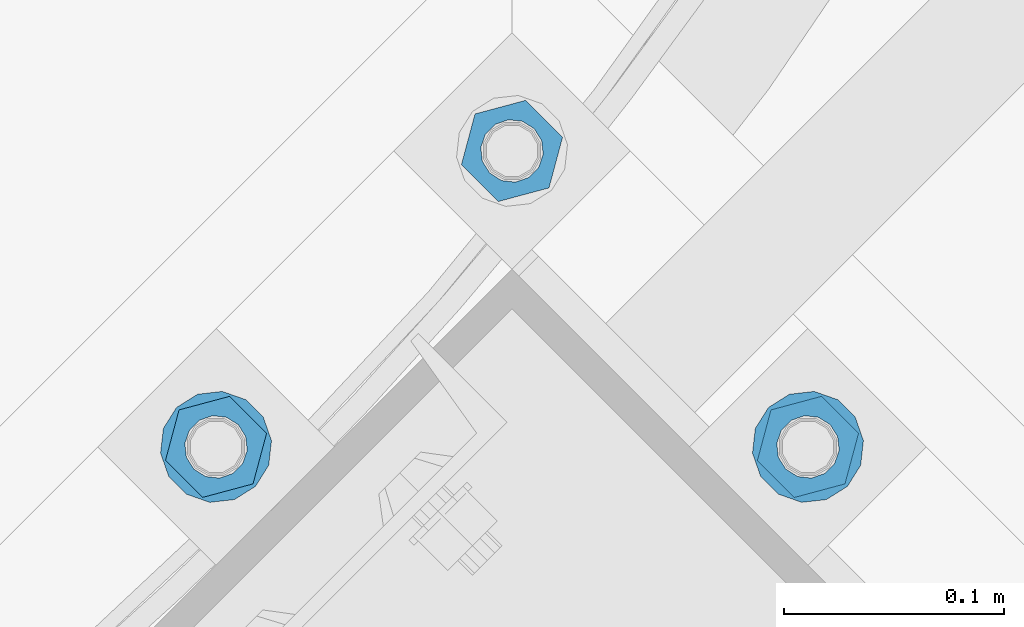
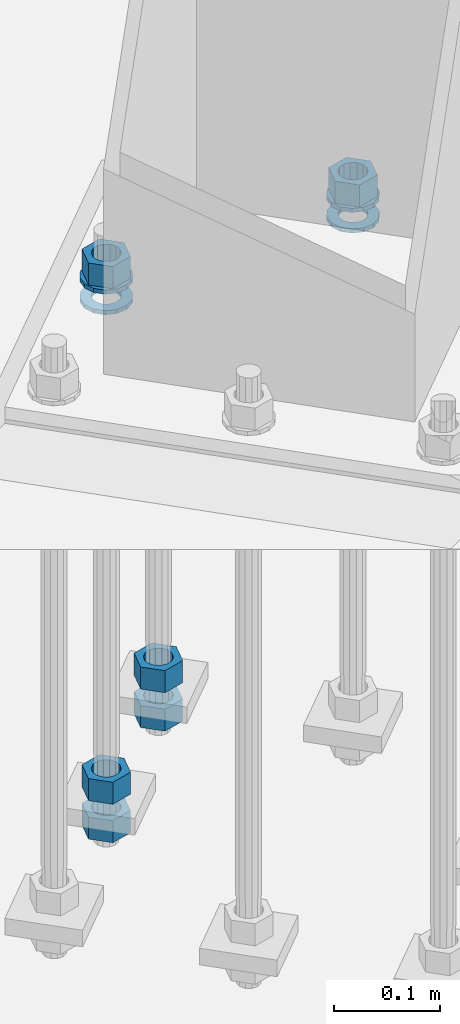
# One storey, part 868 of 1876: 10 columns, 1 element without a shape of its own.
"""IFC2X3 building model written with IfcOpenShell, lengths in millimetres."""

from ifc_helpers import new_model, si_unit, frame, origin_with_axes, place, context, subcontext, project, spatial, faceted_brep, material, type_object, element, aggregate, save


model = new_model("IFC2X3")

# Units and contexts
model_context = context("Model", 3, precision=1e-05, world=origin_with_axes())
body_context = subcontext(model_context, "Body", "Model", "MODEL_VIEW")
ifc_project = project(units=[si_unit("LENGTHUNIT", "METRE", prefix="MILLI"), si_unit("AREAUNIT", "SQUARE_METRE"), si_unit("VOLUMEUNIT", "CUBIC_METRE"), si_unit("MASSUNIT", "GRAM", prefix="KILO"), si_unit("TIMEUNIT", "SECOND"), si_unit("PLANEANGLEUNIT", "RADIAN"), si_unit("SOLIDANGLEUNIT", "STERADIAN"), si_unit("THERMODYNAMICTEMPERATUREUNIT", "DEGREE_CELSIUS"), si_unit("LUMINOUSINTENSITYUNIT", "LUMEN")], contexts=[model_context])

# Site, building, storey
site_placement = place(None, origin_with_axes())
site = spatial("IfcSite", under=ifc_project, at=site_placement, CompositionType="ELEMENT")
building_placement = place(site_placement, origin_with_axes())
building = spatial("IfcBuilding", under=site, at=building_placement, Name="Undefined", CompositionType="ELEMENT")
storey_placement = place(building_placement, origin_with_axes())
storey = spatial("IfcBuildingStorey", under=building, at=storey_placement, Name="Undefined", CompositionType="ELEMENT", Elevation=0.0)

# Assembly, columns
assembly_placement = place(storey_placement, origin_with_axes())
assembly = element("IfcElementAssembly", 1, at=assembly_placement, inside=storey, Name="TEMPLATE", AssemblyPlace="NOTDEFINED", PredefinedType="RIGID_FRAME")
ifc_material_1 = material(Name="STEEL/A563")
column_type_1 = type_object("IfcColumnType", Name="1_HEAVY_HEX_NUT", PredefinedType="NOTDEFINED")
column_1_placement = place(assembly_placement, frame((6714.97873267278, -14852.8285485942, 87.3125), z_axis=(0.707106781186548, 0.707106781186547, 0.0), x_axis=(0.0, 0.0, -1.0)))
column_1 = element("IfcColumn", 2, at=column_1_placement, type_object=column_type_1, material=ifc_material_1, Name="NUT", ObjectType="1_HEAVY_HEX_NUT", context=body_context, shape_type="Brep", body=[
    faceted_brep([(0.0, -23.8099994659442, 9.09494701772928e-13), (0.0, -11.9099998474121, -20.6200008392352), (25.4, -11.9099998474157, -20.6200008392361), (25.4, -23.8099994659478, 0.0), (0.0, 11.9099998474157, -20.620000839237), (25.4, 11.9099998474121, -20.620000839237), (0.0, 23.8099994659478, 9.09494701772928e-13), (25.4, 23.8099994659442, 0.0), (0.0, 11.9099998474157, 20.620000839237), (25.4, 11.9099998474121, 20.620000839237), (0.0, -11.9099998474121, 20.6200008392389), (25.4, -11.9099998474157, 20.6200008392379), (0.0, 1.81898940354586e-12, 14.2899999618567), (0.0, 6.20019861543915, 12.8748450879584), (25.4, 6.20019861543733, 12.8748450879593), (25.4, 0.0, 14.2899999618558), (0.0, 11.1723718546473, 8.90966924477925), (25.4, 11.1723718546436, 8.90966924477925), (0.0, 13.9317198278914, 3.17982413774916), (25.4, 13.9317198278877, 3.17982413775007), (0.0, 13.9317198278914, -3.17982413774644), (25.4, 13.9317198278895, -3.17982413774735), (0.0, 11.1723718546473, -8.90966924477834), (25.4, 11.1723718546455, -8.90966924477925), (0.0, 6.20019861544279, -12.8748450879575), (25.4, 6.20019861543915, -12.8748450879584), (0.0, 3.63797880709171e-12, -14.2899999618548), (25.4, -3.63797880709171e-12, -14.2899999618548), (0.0, -6.20019861543733, -12.8748450879566), (25.4, -6.20019861544097, -12.8748450879584), (0.0, -11.1723718546455, -8.90966924477743), (25.4, -11.1723718546473, -8.90966924477834), (0.0, -13.9317198278877, -3.17982413774735), (25.4, -13.9317198278914, -3.17982413774826), (0.0, -13.9317198278895, 3.17982413774735), (25.4, -13.9317198278914, 3.17982413774826), (0.0, -11.1723718546455, 8.90966924477925), (25.4, -11.1723718546473, 8.90966924478016), (0.0, -6.20019861543915, 12.8748450879593), (25.4, -6.20019861544279, 12.8748450879593)], [[[0, 1, 2, 3]], [[1, 4, 5, 2]], [[4, 6, 7, 5]], [[6, 8, 9, 7]], [[8, 10, 11, 9]], [[10, 0, 3, 11]], [[12, 13, 14, 15]], [[13, 16, 17, 14]], [[16, 18, 19, 17]], [[18, 20, 21, 19]], [[20, 22, 23, 21]], [[22, 24, 25, 23]], [[24, 26, 27, 25]], [[26, 28, 29, 27]], [[28, 30, 31, 29]], [[30, 32, 33, 31]], [[32, 34, 35, 33]], [[34, 36, 37, 35]], [[36, 38, 39, 37]], [[38, 12, 15, 39]], [[5, 7, 9, 11, 3, 2], [17, 19, 21, 23, 25, 27, 29, 31, 33, 35, 37, 39, 15, 14]], [[10, 8, 6, 4, 1, 0], [38, 36, 34, 32, 30, 28, 26, 24, 22, 20, 18, 16, 13, 12]]]),
])
column_2_placement = place(assembly_placement, frame((6580.27489085662, -14718.124706778, -508.0), z_axis=(-0.707106781186547, -0.707106781186548, 0.0), x_axis=(0.0, 0.0, -1.0)))
column_2 = element("IfcColumn", 3, at=column_2_placement, type_object=column_type_1, material=ifc_material_1, Name="NUT", ObjectType="1_HEAVY_HEX_NUT", context=body_context, shape_type="Brep", body=[
    faceted_brep([(0.0, -23.8099994659442, 9.09494701772928e-13), (0.0, -11.9099998474121, -20.6200008392352), (25.4, -11.9099998474157, -20.6200008392361), (25.4, -23.8099994659478, 0.0), (0.0, 11.9099998474157, -20.620000839237), (25.4, 11.9099998474121, -20.620000839237), (0.0, 23.8099994659478, 9.09494701772928e-13), (25.4, 23.8099994659442, 0.0), (0.0, 11.9099998474157, 20.620000839237), (25.4, 11.9099998474121, 20.620000839237), (0.0, -11.9099998474121, 20.6200008392389), (25.4, -11.9099998474157, 20.6200008392379), (0.0, 1.81898940354586e-12, 14.2899999618567), (0.0, 6.20019861543915, 12.8748450879584), (25.4, 6.20019861543733, 12.8748450879593), (25.4, 0.0, 14.2899999618558), (0.0, 11.1723718546473, 8.90966924477925), (25.4, 11.1723718546436, 8.90966924477925), (0.0, 13.9317198278914, 3.17982413774916), (25.4, 13.9317198278877, 3.17982413775007), (0.0, 13.9317198278914, -3.17982413774644), (25.4, 13.9317198278895, -3.17982413774735), (0.0, 11.1723718546473, -8.90966924477834), (25.4, 11.1723718546455, -8.90966924477925), (0.0, 6.20019861544279, -12.8748450879575), (25.4, 6.20019861543915, -12.8748450879584), (0.0, 3.63797880709171e-12, -14.2899999618548), (25.4, -3.63797880709171e-12, -14.2899999618548), (0.0, -6.20019861543733, -12.8748450879566), (25.4, -6.20019861544097, -12.8748450879584), (0.0, -11.1723718546455, -8.90966924477743), (25.4, -11.1723718546473, -8.90966924477834), (0.0, -13.9317198278877, -3.17982413774735), (25.4, -13.9317198278914, -3.17982413774826), (0.0, -13.9317198278895, 3.17982413774735), (25.4, -13.9317198278914, 3.17982413774826), (0.0, -11.1723718546455, 8.90966924477925), (25.4, -11.1723718546473, 8.90966924478016), (0.0, -6.20019861543915, 12.8748450879593), (25.4, -6.20019861544279, 12.8748450879593)], [[[0, 1, 2, 3]], [[1, 4, 5, 2]], [[4, 6, 7, 5]], [[6, 8, 9, 7]], [[8, 10, 11, 9]], [[10, 0, 3, 11]], [[12, 13, 14, 15]], [[13, 16, 17, 14]], [[16, 18, 19, 17]], [[18, 20, 21, 19]], [[20, 22, 23, 21]], [[22, 24, 25, 23]], [[24, 26, 27, 25]], [[26, 28, 29, 27]], [[28, 30, 31, 29]], [[30, 32, 33, 31]], [[32, 34, 35, 33]], [[34, 36, 37, 35]], [[36, 38, 39, 37]], [[38, 12, 15, 39]], [[5, 7, 9, 11, 3, 2], [17, 19, 21, 23, 25, 27, 29, 31, 33, 35, 37, 39, 15, 14]], [[10, 8, 6, 4, 1, 0], [38, 36, 34, 32, 30, 28, 26, 24, 22, 20, 18, 16, 13, 12]]]),
])
column_3_placement = place(assembly_placement, frame((6580.27489085662, -14718.124706778, -552.45), z_axis=(-0.707106781186547, -0.707106781186548, 0.0), x_axis=(0.0, 0.0, -1.0)))
column_3 = element("IfcColumn", 4, at=column_3_placement, type_object=column_type_1, material=ifc_material_1, Name="NUT", ObjectType="1_HEAVY_HEX_NUT", context=body_context, shape_type="Brep", body=[
    faceted_brep([(0.0, -23.8099994659442, 9.09494701772928e-13), (0.0, -11.9099998474121, -20.6200008392352), (25.4, -11.9099998474157, -20.6200008392361), (25.4, -23.8099994659478, 0.0), (0.0, 11.9099998474157, -20.620000839237), (25.4, 11.9099998474121, -20.620000839237), (0.0, 23.8099994659478, 9.09494701772928e-13), (25.4, 23.8099994659442, 0.0), (0.0, 11.9099998474157, 20.620000839237), (25.4, 11.9099998474121, 20.620000839237), (0.0, -11.9099998474121, 20.6200008392389), (25.4, -11.9099998474157, 20.6200008392379), (0.0, 1.81898940354586e-12, 14.2899999618567), (0.0, 6.20019861543915, 12.8748450879584), (25.4, 6.20019861543733, 12.8748450879593), (25.4, 0.0, 14.2899999618558), (0.0, 11.1723718546473, 8.90966924477925), (25.4, 11.1723718546436, 8.90966924477925), (0.0, 13.9317198278914, 3.17982413774916), (25.4, 13.9317198278877, 3.17982413775007), (0.0, 13.9317198278914, -3.17982413774644), (25.4, 13.9317198278895, -3.17982413774735), (0.0, 11.1723718546473, -8.90966924477834), (25.4, 11.1723718546455, -8.90966924477925), (0.0, 6.20019861544279, -12.8748450879575), (25.4, 6.20019861543915, -12.8748450879584), (0.0, 3.63797880709171e-12, -14.2899999618548), (25.4, -3.63797880709171e-12, -14.2899999618548), (0.0, -6.20019861543733, -12.8748450879566), (25.4, -6.20019861544097, -12.8748450879584), (0.0, -11.1723718546455, -8.90966924477743), (25.4, -11.1723718546473, -8.90966924477834), (0.0, -13.9317198278877, -3.17982413774735), (25.4, -13.9317198278914, -3.17982413774826), (0.0, -13.9317198278895, 3.17982413774735), (25.4, -13.9317198278914, 3.17982413774826), (0.0, -11.1723718546455, 8.90966924477925), (25.4, -11.1723718546473, 8.90966924478016), (0.0, -6.20019861543915, 12.8748450879593), (25.4, -6.20019861544279, 12.8748450879593)], [[[0, 1, 2, 3]], [[1, 4, 5, 2]], [[4, 6, 7, 5]], [[6, 8, 9, 7]], [[8, 10, 11, 9]], [[10, 0, 3, 11]], [[12, 13, 14, 15]], [[13, 16, 17, 14]], [[16, 18, 19, 17]], [[18, 20, 21, 19]], [[20, 22, 23, 21]], [[22, 24, 25, 23]], [[24, 26, 27, 25]], [[26, 28, 29, 27]], [[28, 30, 31, 29]], [[30, 32, 33, 31]], [[32, 34, 35, 33]], [[34, 36, 37, 35]], [[36, 38, 39, 37]], [[38, 12, 15, 39]], [[5, 7, 9, 11, 3, 2], [17, 19, 21, 23, 25, 27, 29, 31, 33, 35, 37, 39, 15, 14]], [[10, 8, 6, 4, 1, 0], [38, 36, 34, 32, 30, 28, 26, 24, 22, 20, 18, 16, 13, 12]]]),
])
column_4_placement = place(assembly_placement, frame((6445.57104904047, -14852.8285485942, 87.3125), z_axis=(-0.707106781186547, -0.707106781186548, 0.0), x_axis=(0.0, 0.0, -1.0)))
column_4 = element("IfcColumn", 5, at=column_4_placement, type_object=column_type_1, material=ifc_material_1, Name="NUT", ObjectType="1_HEAVY_HEX_NUT", context=body_context, shape_type="Brep", body=[
    faceted_brep([(0.0, -23.8099994659442, 9.09494701772928e-13), (0.0, -11.9099998474121, -20.6200008392352), (25.4, -11.9099998474157, -20.6200008392361), (25.4, -23.8099994659478, 0.0), (0.0, 11.9099998474157, -20.620000839237), (25.4, 11.9099998474121, -20.620000839237), (0.0, 23.8099994659478, 9.09494701772928e-13), (25.4, 23.8099994659442, 0.0), (0.0, 11.9099998474157, 20.620000839237), (25.4, 11.9099998474121, 20.620000839237), (0.0, -11.9099998474121, 20.6200008392389), (25.4, -11.9099998474157, 20.6200008392379), (0.0, 1.81898940354586e-12, 14.2899999618567), (0.0, 6.20019861543915, 12.8748450879584), (25.4, 6.20019861543733, 12.8748450879593), (25.4, 0.0, 14.2899999618558), (0.0, 11.1723718546473, 8.90966924477925), (25.4, 11.1723718546436, 8.90966924477925), (0.0, 13.9317198278914, 3.17982413774916), (25.4, 13.9317198278877, 3.17982413775007), (0.0, 13.9317198278914, -3.17982413774644), (25.4, 13.9317198278895, -3.17982413774735), (0.0, 11.1723718546473, -8.90966924477834), (25.4, 11.1723718546455, -8.90966924477925), (0.0, 6.20019861544279, -12.8748450879575), (25.4, 6.20019861543915, -12.8748450879584), (0.0, 3.63797880709171e-12, -14.2899999618548), (25.4, -3.63797880709171e-12, -14.2899999618548), (0.0, -6.20019861543733, -12.8748450879566), (25.4, -6.20019861544097, -12.8748450879584), (0.0, -11.1723718546455, -8.90966924477743), (25.4, -11.1723718546473, -8.90966924477834), (0.0, -13.9317198278877, -3.17982413774735), (25.4, -13.9317198278914, -3.17982413774826), (0.0, -13.9317198278895, 3.17982413774735), (25.4, -13.9317198278914, 3.17982413774826), (0.0, -11.1723718546455, 8.90966924477925), (25.4, -11.1723718546473, 8.90966924478016), (0.0, -6.20019861543915, 12.8748450879593), (25.4, -6.20019861544279, 12.8748450879593)], [[[0, 1, 2, 3]], [[1, 4, 5, 2]], [[4, 6, 7, 5]], [[6, 8, 9, 7]], [[8, 10, 11, 9]], [[10, 0, 3, 11]], [[12, 13, 14, 15]], [[13, 16, 17, 14]], [[16, 18, 19, 17]], [[18, 20, 21, 19]], [[20, 22, 23, 21]], [[22, 24, 25, 23]], [[24, 26, 27, 25]], [[26, 28, 29, 27]], [[28, 30, 31, 29]], [[30, 32, 33, 31]], [[32, 34, 35, 33]], [[34, 36, 37, 35]], [[36, 38, 39, 37]], [[38, 12, 15, 39]], [[5, 7, 9, 11, 3, 2], [17, 19, 21, 23, 25, 27, 29, 31, 33, 35, 37, 39, 15, 14]], [[10, 8, 6, 4, 1, 0], [38, 36, 34, 32, 30, 28, 26, 24, 22, 20, 18, 16, 13, 12]]]),
])
column_5_placement = place(assembly_placement, frame((6445.57104904047, -14852.8285485942, -508.0), z_axis=(-0.707106781186547, -0.707106781186548, 0.0), x_axis=(0.0, 0.0, -1.0)))
column_5 = element("IfcColumn", 6, at=column_5_placement, type_object=column_type_1, material=ifc_material_1, Name="NUT", ObjectType="1_HEAVY_HEX_NUT", context=body_context, shape_type="Brep", body=[
    faceted_brep([(0.0, -23.8099994659442, 9.09494701772928e-13), (0.0, -11.9099998474121, -20.6200008392352), (25.4, -11.9099998474157, -20.6200008392361), (25.4, -23.8099994659478, 0.0), (0.0, 11.9099998474157, -20.620000839237), (25.4, 11.9099998474121, -20.620000839237), (0.0, 23.8099994659478, 9.09494701772928e-13), (25.4, 23.8099994659442, 0.0), (0.0, 11.9099998474157, 20.620000839237), (25.4, 11.9099998474121, 20.620000839237), (0.0, -11.9099998474121, 20.6200008392389), (25.4, -11.9099998474157, 20.6200008392379), (0.0, 1.81898940354586e-12, 14.2899999618567), (0.0, 6.20019861543915, 12.8748450879584), (25.4, 6.20019861543733, 12.8748450879593), (25.4, 0.0, 14.2899999618558), (0.0, 11.1723718546473, 8.90966924477925), (25.4, 11.1723718546436, 8.90966924477925), (0.0, 13.9317198278914, 3.17982413774916), (25.4, 13.9317198278877, 3.17982413775007), (0.0, 13.9317198278914, -3.17982413774644), (25.4, 13.9317198278895, -3.17982413774735), (0.0, 11.1723718546473, -8.90966924477834), (25.4, 11.1723718546455, -8.90966924477925), (0.0, 6.20019861544279, -12.8748450879575), (25.4, 6.20019861543915, -12.8748450879584), (0.0, 3.63797880709171e-12, -14.2899999618548), (25.4, -3.63797880709171e-12, -14.2899999618548), (0.0, -6.20019861543733, -12.8748450879566), (25.4, -6.20019861544097, -12.8748450879584), (0.0, -11.1723718546455, -8.90966924477743), (25.4, -11.1723718546473, -8.90966924477834), (0.0, -13.9317198278877, -3.17982413774735), (25.4, -13.9317198278914, -3.17982413774826), (0.0, -13.9317198278895, 3.17982413774735), (25.4, -13.9317198278914, 3.17982413774826), (0.0, -11.1723718546455, 8.90966924477925), (25.4, -11.1723718546473, 8.90966924478016), (0.0, -6.20019861543915, 12.8748450879593), (25.4, -6.20019861544279, 12.8748450879593)], [[[0, 1, 2, 3]], [[1, 4, 5, 2]], [[4, 6, 7, 5]], [[6, 8, 9, 7]], [[8, 10, 11, 9]], [[10, 0, 3, 11]], [[12, 13, 14, 15]], [[13, 16, 17, 14]], [[16, 18, 19, 17]], [[18, 20, 21, 19]], [[20, 22, 23, 21]], [[22, 24, 25, 23]], [[24, 26, 27, 25]], [[26, 28, 29, 27]], [[28, 30, 31, 29]], [[30, 32, 33, 31]], [[32, 34, 35, 33]], [[34, 36, 37, 35]], [[36, 38, 39, 37]], [[38, 12, 15, 39]], [[5, 7, 9, 11, 3, 2], [17, 19, 21, 23, 25, 27, 29, 31, 33, 35, 37, 39, 15, 14]], [[10, 8, 6, 4, 1, 0], [38, 36, 34, 32, 30, 28, 26, 24, 22, 20, 18, 16, 13, 12]]]),
])
column_6_placement = place(assembly_placement, frame((6445.57104904047, -14852.8285485942, -552.45), z_axis=(-0.707106781186547, -0.707106781186548, 0.0), x_axis=(0.0, 0.0, -1.0)))
column_6 = element("IfcColumn", 7, at=column_6_placement, type_object=column_type_1, material=ifc_material_1, Name="NUT", ObjectType="1_HEAVY_HEX_NUT", context=body_context, shape_type="Brep", body=[
    faceted_brep([(0.0, -23.8099994659442, 9.09494701772928e-13), (0.0, -11.9099998474121, -20.6200008392352), (25.4, -11.9099998474157, -20.6200008392361), (25.4, -23.8099994659478, 0.0), (0.0, 11.9099998474157, -20.620000839237), (25.4, 11.9099998474121, -20.620000839237), (0.0, 23.8099994659478, 9.09494701772928e-13), (25.4, 23.8099994659442, 0.0), (0.0, 11.9099998474157, 20.620000839237), (25.4, 11.9099998474121, 20.620000839237), (0.0, -11.9099998474121, 20.6200008392389), (25.4, -11.9099998474157, 20.6200008392379), (0.0, 1.81898940354586e-12, 14.2899999618567), (0.0, 6.20019861543915, 12.8748450879584), (25.4, 6.20019861543733, 12.8748450879593), (25.4, 0.0, 14.2899999618558), (0.0, 11.1723718546473, 8.90966924477925), (25.4, 11.1723718546436, 8.90966924477925), (0.0, 13.9317198278914, 3.17982413774916), (25.4, 13.9317198278877, 3.17982413775007), (0.0, 13.9317198278914, -3.17982413774644), (25.4, 13.9317198278895, -3.17982413774735), (0.0, 11.1723718546473, -8.90966924477834), (25.4, 11.1723718546455, -8.90966924477925), (0.0, 6.20019861544279, -12.8748450879575), (25.4, 6.20019861543915, -12.8748450879584), (0.0, 3.63797880709171e-12, -14.2899999618548), (25.4, -3.63797880709171e-12, -14.2899999618548), (0.0, -6.20019861543733, -12.8748450879566), (25.4, -6.20019861544097, -12.8748450879584), (0.0, -11.1723718546455, -8.90966924477743), (25.4, -11.1723718546473, -8.90966924477834), (0.0, -13.9317198278877, -3.17982413774735), (25.4, -13.9317198278914, -3.17982413774826), (0.0, -13.9317198278895, 3.17982413774735), (25.4, -13.9317198278914, 3.17982413774826), (0.0, -11.1723718546455, 8.90966924477925), (25.4, -11.1723718546473, 8.90966924478016), (0.0, -6.20019861543915, 12.8748450879593), (25.4, -6.20019861544279, 12.8748450879593)], [[[0, 1, 2, 3]], [[1, 4, 5, 2]], [[4, 6, 7, 5]], [[6, 8, 9, 7]], [[8, 10, 11, 9]], [[10, 0, 3, 11]], [[12, 13, 14, 15]], [[13, 16, 17, 14]], [[16, 18, 19, 17]], [[18, 20, 21, 19]], [[20, 22, 23, 21]], [[22, 24, 25, 23]], [[24, 26, 27, 25]], [[26, 28, 29, 27]], [[28, 30, 31, 29]], [[30, 32, 33, 31]], [[32, 34, 35, 33]], [[34, 36, 37, 35]], [[36, 38, 39, 37]], [[38, 12, 15, 39]], [[5, 7, 9, 11, 3, 2], [17, 19, 21, 23, 25, 27, 29, 31, 33, 35, 37, 39, 15, 14]], [[10, 8, 6, 4, 1, 0], [38, 36, 34, 32, 30, 28, 26, 24, 22, 20, 18, 16, 13, 12]]]),
])
ifc_material_2 = material(Name="STEEL/F436")
column_type_2 = type_object("IfcColumnType", Name="1_WASHER", PredefinedType="NOTDEFINED")
column_7_placement = place(assembly_placement, frame((6714.97873267278, -14852.8285485942, 38.1), z_axis=(0.707106781186548, 0.707106781186547, 0.0), x_axis=(0.0, 0.0, -1.0)))
column_7 = element("IfcColumn", 8, at=column_7_placement, type_object=column_type_2, material=ifc_material_2, Name="WASHER", ObjectType="1_WASHER", context=body_context, shape_type="Brep", body=[
    faceted_brep([(0.0, -25.3999996185375, 0.0), (0.0, -22.8846089010331, -11.0206468080742), (4.7625, -22.8846089010331, -11.0206468080742), (4.7625, -25.3999996185375, 0.0), (0.0, -15.8366407293743, -19.8585193564477), (4.7625, -15.8366407293743, -19.8585193564477), (0.0, -5.65203163760816, -24.7631685975166), (4.7625, -5.65203163760816, -24.7631685975166), (0.0, 5.65203163760452, -24.7631685975166), (4.7625, 5.65203163760452, -24.7631685975166), (0.0, 15.8366407293706, -19.858519356445), (4.7625, 15.8366407293706, -19.858519356445), (0.0, 22.8846089010331, -11.0206468080733), (4.7625, 22.8846089010331, -11.0206468080733), (0.0, 25.3999996185339, 9.09494701772928e-13), (4.7625, 25.3999996185339, 9.09494701772928e-13), (0.0, 22.8846089010331, 11.0206468080751), (4.7625, 22.8846089010331, 11.0206468080751), (0.0, 15.8366407293706, 19.8585193564486), (4.7625, 15.8366407293706, 19.8585193564486), (0.0, 5.65203163760452, 24.7631685975175), (4.7625, 5.65203163760452, 24.7631685975175), (0.0, -5.65203163760816, 24.7631685975175), (4.7625, -5.65203163760816, 24.7631685975175), (0.0, -15.8366407293724, 19.8585193564459), (4.7625, -15.8366407293724, 19.8585193564459), (0.0, -22.8846089010367, 11.0206468080751), (4.7625, -22.8846089010367, 11.0206468080751), (0.0, 1.81898940354586e-12, 14.2899999618567), (0.0, 6.20019861543915, 12.8748450879584), (4.7625, 6.20019861543733, 12.8748450879593), (4.7625, 0.0, 14.2899999618558), (0.0, 11.1723718546473, 8.90966924477925), (4.7625, 11.1723718546436, 8.90966924477925), (0.0, 13.9317198278914, 3.17982413774916), (4.7625, 13.9317198278877, 3.17982413775007), (0.0, 13.9317198278914, -3.17982413774644), (4.7625, 13.9317198278895, -3.17982413774735), (0.0, 11.1723718546473, -8.90966924477834), (4.7625, 11.1723718546455, -8.90966924477925), (0.0, 6.20019861544279, -12.8748450879575), (4.7625, 6.20019861543915, -12.8748450879584), (0.0, 3.63797880709171e-12, -14.2899999618548), (4.7625, -3.63797880709171e-12, -14.2899999618548), (0.0, -6.20019861543733, -12.8748450879566), (4.7625, -6.20019861544097, -12.8748450879584), (0.0, -11.1723718546455, -8.90966924477743), (4.7625, -11.1723718546473, -8.90966924477834), (0.0, -13.9317198278877, -3.17982413774735), (4.7625, -13.9317198278914, -3.17982413774826), (0.0, -13.9317198278895, 3.17982413774735), (4.7625, -13.9317198278914, 3.17982413774826), (0.0, -11.1723718546455, 8.90966924477925), (4.7625, -11.1723718546473, 8.90966924478016), (0.0, -6.20019861543915, 12.8748450879593), (4.7625, -6.20019861544279, 12.8748450879593)], [[[0, 1, 2, 3]], [[1, 4, 5, 2]], [[4, 6, 7, 5]], [[6, 8, 9, 7]], [[8, 10, 11, 9]], [[10, 12, 13, 11]], [[12, 14, 15, 13]], [[14, 16, 17, 15]], [[16, 18, 19, 17]], [[18, 20, 21, 19]], [[20, 22, 23, 21]], [[22, 24, 25, 23]], [[24, 26, 27, 25]], [[26, 0, 3, 27]], [[28, 29, 30, 31]], [[29, 32, 33, 30]], [[32, 34, 35, 33]], [[34, 36, 37, 35]], [[36, 38, 39, 37]], [[38, 40, 41, 39]], [[40, 42, 43, 41]], [[42, 44, 45, 43]], [[44, 46, 47, 45]], [[46, 48, 49, 47]], [[48, 50, 51, 49]], [[50, 52, 53, 51]], [[52, 54, 55, 53]], [[54, 28, 31, 55]], [[5, 7, 9, 11, 13, 15, 17, 19, 21, 23, 25, 27, 3, 2], [33, 35, 37, 39, 41, 43, 45, 47, 49, 51, 53, 55, 31, 30]], [[26, 24, 22, 20, 18, 16, 14, 12, 10, 8, 6, 4, 1, 0], [54, 52, 50, 48, 46, 44, 42, 40, 38, 36, 34, 32, 29, 28]]]),
])
column_8_placement = place(assembly_placement, frame((6714.97873267278, -14852.8285485942, 61.9125), z_axis=(0.707106781186548, 0.707106781186547, 0.0), x_axis=(0.0, 0.0, -1.0)))
column_8 = element("IfcColumn", 9, at=column_8_placement, type_object=column_type_2, material=ifc_material_2, Name="WASHER", ObjectType="1_WASHER", context=body_context, shape_type="Brep", body=[
    faceted_brep([(0.0, -25.3999996185375, 0.0), (0.0, -22.8846089010331, -11.0206468080742), (4.7625, -22.8846089010331, -11.0206468080742), (4.7625, -25.3999996185375, 0.0), (0.0, -15.8366407293743, -19.8585193564477), (4.7625, -15.8366407293743, -19.8585193564477), (0.0, -5.65203163760816, -24.7631685975166), (4.7625, -5.65203163760816, -24.7631685975166), (0.0, 5.65203163760452, -24.7631685975166), (4.7625, 5.65203163760452, -24.7631685975166), (0.0, 15.8366407293706, -19.858519356445), (4.7625, 15.8366407293706, -19.858519356445), (0.0, 22.8846089010331, -11.0206468080733), (4.7625, 22.8846089010331, -11.0206468080733), (0.0, 25.3999996185339, 9.09494701772928e-13), (4.7625, 25.3999996185339, 9.09494701772928e-13), (0.0, 22.8846089010331, 11.0206468080751), (4.7625, 22.8846089010331, 11.0206468080751), (0.0, 15.8366407293706, 19.8585193564486), (4.7625, 15.8366407293706, 19.8585193564486), (0.0, 5.65203163760452, 24.7631685975175), (4.7625, 5.65203163760452, 24.7631685975175), (0.0, -5.65203163760816, 24.7631685975175), (4.7625, -5.65203163760816, 24.7631685975175), (0.0, -15.8366407293724, 19.8585193564459), (4.7625, -15.8366407293724, 19.8585193564459), (0.0, -22.8846089010367, 11.0206468080751), (4.7625, -22.8846089010367, 11.0206468080751), (0.0, 1.81898940354586e-12, 14.2899999618567), (0.0, 6.20019861543915, 12.8748450879584), (4.7625, 6.20019861543733, 12.8748450879593), (4.7625, 0.0, 14.2899999618558), (0.0, 11.1723718546473, 8.90966924477925), (4.7625, 11.1723718546436, 8.90966924477925), (0.0, 13.9317198278914, 3.17982413774916), (4.7625, 13.9317198278877, 3.17982413775007), (0.0, 13.9317198278914, -3.17982413774644), (4.7625, 13.9317198278895, -3.17982413774735), (0.0, 11.1723718546473, -8.90966924477834), (4.7625, 11.1723718546455, -8.90966924477925), (0.0, 6.20019861544279, -12.8748450879575), (4.7625, 6.20019861543915, -12.8748450879584), (0.0, 3.63797880709171e-12, -14.2899999618548), (4.7625, -3.63797880709171e-12, -14.2899999618548), (0.0, -6.20019861543733, -12.8748450879566), (4.7625, -6.20019861544097, -12.8748450879584), (0.0, -11.1723718546455, -8.90966924477743), (4.7625, -11.1723718546473, -8.90966924477834), (0.0, -13.9317198278877, -3.17982413774735), (4.7625, -13.9317198278914, -3.17982413774826), (0.0, -13.9317198278895, 3.17982413774735), (4.7625, -13.9317198278914, 3.17982413774826), (0.0, -11.1723718546455, 8.90966924477925), (4.7625, -11.1723718546473, 8.90966924478016), (0.0, -6.20019861543915, 12.8748450879593), (4.7625, -6.20019861544279, 12.8748450879593)], [[[0, 1, 2, 3]], [[1, 4, 5, 2]], [[4, 6, 7, 5]], [[6, 8, 9, 7]], [[8, 10, 11, 9]], [[10, 12, 13, 11]], [[12, 14, 15, 13]], [[14, 16, 17, 15]], [[16, 18, 19, 17]], [[18, 20, 21, 19]], [[20, 22, 23, 21]], [[22, 24, 25, 23]], [[24, 26, 27, 25]], [[26, 0, 3, 27]], [[28, 29, 30, 31]], [[29, 32, 33, 30]], [[32, 34, 35, 33]], [[34, 36, 37, 35]], [[36, 38, 39, 37]], [[38, 40, 41, 39]], [[40, 42, 43, 41]], [[42, 44, 45, 43]], [[44, 46, 47, 45]], [[46, 48, 49, 47]], [[48, 50, 51, 49]], [[50, 52, 53, 51]], [[52, 54, 55, 53]], [[54, 28, 31, 55]], [[5, 7, 9, 11, 13, 15, 17, 19, 21, 23, 25, 27, 3, 2], [33, 35, 37, 39, 41, 43, 45, 47, 49, 51, 53, 55, 31, 30]], [[26, 24, 22, 20, 18, 16, 14, 12, 10, 8, 6, 4, 1, 0], [54, 52, 50, 48, 46, 44, 42, 40, 38, 36, 34, 32, 29, 28]]]),
])
column_9_placement = place(assembly_placement, frame((6445.57104904047, -14852.8285485942, 38.1), z_axis=(-0.707106781186547, -0.707106781186548, 0.0), x_axis=(0.0, 0.0, -1.0)))
column_9 = element("IfcColumn", 10, at=column_9_placement, type_object=column_type_2, material=ifc_material_2, Name="WASHER", ObjectType="1_WASHER", context=body_context, shape_type="Brep", body=[
    faceted_brep([(0.0, -25.3999996185375, 0.0), (0.0, -22.8846089010331, -11.0206468080742), (4.7625, -22.8846089010331, -11.0206468080742), (4.7625, -25.3999996185375, 0.0), (0.0, -15.8366407293743, -19.8585193564477), (4.7625, -15.8366407293743, -19.8585193564477), (0.0, -5.65203163760816, -24.7631685975166), (4.7625, -5.65203163760816, -24.7631685975166), (0.0, 5.65203163760452, -24.7631685975166), (4.7625, 5.65203163760452, -24.7631685975166), (0.0, 15.8366407293706, -19.858519356445), (4.7625, 15.8366407293706, -19.858519356445), (0.0, 22.8846089010331, -11.0206468080733), (4.7625, 22.8846089010331, -11.0206468080733), (0.0, 25.3999996185339, 9.09494701772928e-13), (4.7625, 25.3999996185339, 9.09494701772928e-13), (0.0, 22.8846089010331, 11.0206468080751), (4.7625, 22.8846089010331, 11.0206468080751), (0.0, 15.8366407293706, 19.8585193564486), (4.7625, 15.8366407293706, 19.8585193564486), (0.0, 5.65203163760452, 24.7631685975175), (4.7625, 5.65203163760452, 24.7631685975175), (0.0, -5.65203163760816, 24.7631685975175), (4.7625, -5.65203163760816, 24.7631685975175), (0.0, -15.8366407293724, 19.8585193564459), (4.7625, -15.8366407293724, 19.8585193564459), (0.0, -22.8846089010367, 11.0206468080751), (4.7625, -22.8846089010367, 11.0206468080751), (0.0, 1.81898940354586e-12, 14.2899999618567), (0.0, 6.20019861543915, 12.8748450879584), (4.7625, 6.20019861543733, 12.8748450879593), (4.7625, 0.0, 14.2899999618558), (0.0, 11.1723718546473, 8.90966924477925), (4.7625, 11.1723718546436, 8.90966924477925), (0.0, 13.9317198278914, 3.17982413774916), (4.7625, 13.9317198278877, 3.17982413775007), (0.0, 13.9317198278914, -3.17982413774644), (4.7625, 13.9317198278895, -3.17982413774735), (0.0, 11.1723718546473, -8.90966924477834), (4.7625, 11.1723718546455, -8.90966924477925), (0.0, 6.20019861544279, -12.8748450879575), (4.7625, 6.20019861543915, -12.8748450879584), (0.0, 3.63797880709171e-12, -14.2899999618548), (4.7625, -3.63797880709171e-12, -14.2899999618548), (0.0, -6.20019861543733, -12.8748450879566), (4.7625, -6.20019861544097, -12.8748450879584), (0.0, -11.1723718546455, -8.90966924477743), (4.7625, -11.1723718546473, -8.90966924477834), (0.0, -13.9317198278877, -3.17982413774735), (4.7625, -13.9317198278914, -3.17982413774826), (0.0, -13.9317198278895, 3.17982413774735), (4.7625, -13.9317198278914, 3.17982413774826), (0.0, -11.1723718546455, 8.90966924477925), (4.7625, -11.1723718546473, 8.90966924478016), (0.0, -6.20019861543915, 12.8748450879593), (4.7625, -6.20019861544279, 12.8748450879593)], [[[0, 1, 2, 3]], [[1, 4, 5, 2]], [[4, 6, 7, 5]], [[6, 8, 9, 7]], [[8, 10, 11, 9]], [[10, 12, 13, 11]], [[12, 14, 15, 13]], [[14, 16, 17, 15]], [[16, 18, 19, 17]], [[18, 20, 21, 19]], [[20, 22, 23, 21]], [[22, 24, 25, 23]], [[24, 26, 27, 25]], [[26, 0, 3, 27]], [[28, 29, 30, 31]], [[29, 32, 33, 30]], [[32, 34, 35, 33]], [[34, 36, 37, 35]], [[36, 38, 39, 37]], [[38, 40, 41, 39]], [[40, 42, 43, 41]], [[42, 44, 45, 43]], [[44, 46, 47, 45]], [[46, 48, 49, 47]], [[48, 50, 51, 49]], [[50, 52, 53, 51]], [[52, 54, 55, 53]], [[54, 28, 31, 55]], [[5, 7, 9, 11, 13, 15, 17, 19, 21, 23, 25, 27, 3, 2], [33, 35, 37, 39, 41, 43, 45, 47, 49, 51, 53, 55, 31, 30]], [[26, 24, 22, 20, 18, 16, 14, 12, 10, 8, 6, 4, 1, 0], [54, 52, 50, 48, 46, 44, 42, 40, 38, 36, 34, 32, 29, 28]]]),
])
column_10_placement = place(assembly_placement, frame((6445.57104904047, -14852.8285485942, 61.9125), z_axis=(-0.707106781186547, -0.707106781186548, 0.0), x_axis=(0.0, 0.0, -1.0)))
column_10 = element("IfcColumn", 11, at=column_10_placement, type_object=column_type_2, material=ifc_material_2, Name="WASHER", ObjectType="1_WASHER", context=body_context, shape_type="Brep", body=[
    faceted_brep([(0.0, -25.3999996185375, 0.0), (0.0, -22.8846089010331, -11.0206468080742), (4.7625, -22.8846089010331, -11.0206468080742), (4.7625, -25.3999996185375, 0.0), (0.0, -15.8366407293743, -19.8585193564477), (4.7625, -15.8366407293743, -19.8585193564477), (0.0, -5.65203163760816, -24.7631685975166), (4.7625, -5.65203163760816, -24.7631685975166), (0.0, 5.65203163760452, -24.7631685975166), (4.7625, 5.65203163760452, -24.7631685975166), (0.0, 15.8366407293706, -19.858519356445), (4.7625, 15.8366407293706, -19.858519356445), (0.0, 22.8846089010331, -11.0206468080733), (4.7625, 22.8846089010331, -11.0206468080733), (0.0, 25.3999996185339, 9.09494701772928e-13), (4.7625, 25.3999996185339, 9.09494701772928e-13), (0.0, 22.8846089010331, 11.0206468080751), (4.7625, 22.8846089010331, 11.0206468080751), (0.0, 15.8366407293706, 19.8585193564486), (4.7625, 15.8366407293706, 19.8585193564486), (0.0, 5.65203163760452, 24.7631685975175), (4.7625, 5.65203163760452, 24.7631685975175), (0.0, -5.65203163760816, 24.7631685975175), (4.7625, -5.65203163760816, 24.7631685975175), (0.0, -15.8366407293724, 19.8585193564459), (4.7625, -15.8366407293724, 19.8585193564459), (0.0, -22.8846089010367, 11.0206468080751), (4.7625, -22.8846089010367, 11.0206468080751), (0.0, 1.81898940354586e-12, 14.2899999618567), (0.0, 6.20019861543915, 12.8748450879584), (4.7625, 6.20019861543733, 12.8748450879593), (4.7625, 0.0, 14.2899999618558), (0.0, 11.1723718546473, 8.90966924477925), (4.7625, 11.1723718546436, 8.90966924477925), (0.0, 13.9317198278914, 3.17982413774916), (4.7625, 13.9317198278877, 3.17982413775007), (0.0, 13.9317198278914, -3.17982413774644), (4.7625, 13.9317198278895, -3.17982413774735), (0.0, 11.1723718546473, -8.90966924477834), (4.7625, 11.1723718546455, -8.90966924477925), (0.0, 6.20019861544279, -12.8748450879575), (4.7625, 6.20019861543915, -12.8748450879584), (0.0, 3.63797880709171e-12, -14.2899999618548), (4.7625, -3.63797880709171e-12, -14.2899999618548), (0.0, -6.20019861543733, -12.8748450879566), (4.7625, -6.20019861544097, -12.8748450879584), (0.0, -11.1723718546455, -8.90966924477743), (4.7625, -11.1723718546473, -8.90966924477834), (0.0, -13.9317198278877, -3.17982413774735), (4.7625, -13.9317198278914, -3.17982413774826), (0.0, -13.9317198278895, 3.17982413774735), (4.7625, -13.9317198278914, 3.17982413774826), (0.0, -11.1723718546455, 8.90966924477925), (4.7625, -11.1723718546473, 8.90966924478016), (0.0, -6.20019861543915, 12.8748450879593), (4.7625, -6.20019861544279, 12.8748450879593)], [[[0, 1, 2, 3]], [[1, 4, 5, 2]], [[4, 6, 7, 5]], [[6, 8, 9, 7]], [[8, 10, 11, 9]], [[10, 12, 13, 11]], [[12, 14, 15, 13]], [[14, 16, 17, 15]], [[16, 18, 19, 17]], [[18, 20, 21, 19]], [[20, 22, 23, 21]], [[22, 24, 25, 23]], [[24, 26, 27, 25]], [[26, 0, 3, 27]], [[28, 29, 30, 31]], [[29, 32, 33, 30]], [[32, 34, 35, 33]], [[34, 36, 37, 35]], [[36, 38, 39, 37]], [[38, 40, 41, 39]], [[40, 42, 43, 41]], [[42, 44, 45, 43]], [[44, 46, 47, 45]], [[46, 48, 49, 47]], [[48, 50, 51, 49]], [[50, 52, 53, 51]], [[52, 54, 55, 53]], [[54, 28, 31, 55]], [[5, 7, 9, 11, 13, 15, 17, 19, 21, 23, 25, 27, 3, 2], [33, 35, 37, 39, 41, 43, 45, 47, 49, 51, 53, 55, 31, 30]], [[26, 24, 22, 20, 18, 16, 14, 12, 10, 8, 6, 4, 1, 0], [54, 52, 50, 48, 46, 44, 42, 40, 38, 36, 34, 32, 29, 28]]]),
])
aggregate(assembly, [column_1, column_7, column_8, column_2, column_3, column_4, column_9, column_10, column_5, column_6])

save(model, "model.ifc")
